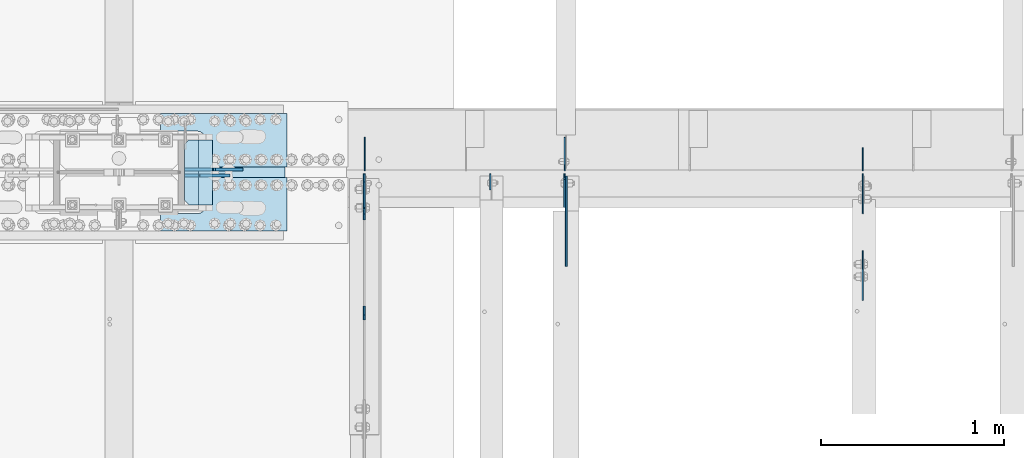
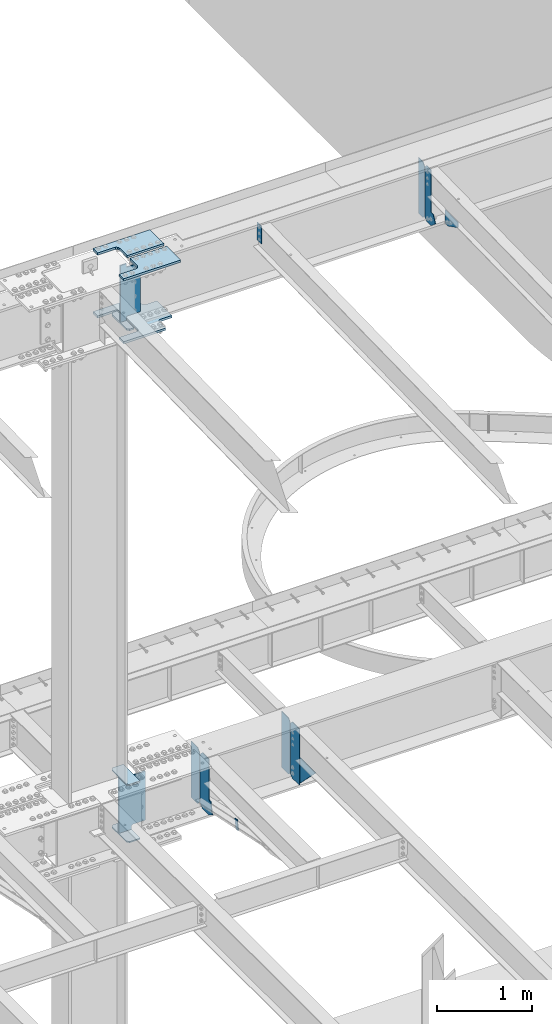
# One storey, part 1619 of 1763: 18 plates, 9 elements without a shape of their own.
"""IFC2X3 building model written with IfcOpenShell, lengths in millimetres."""

import ifcopenshell
import ifcopenshell.guid

model = None  # the IFC model being written
_history = None  # IfcOwnerHistory: only IFC2X3 demands one
_inside = {}  # id of a spatial element -> (the spatial element, [elements in it])
_under = {}  # id of a project, library or spatial element -> (it, [spatial elements below it])
_declared = {}  # id of a project -> (the project, [libraries it declares])
_typed = {}  # id of a type object -> (the type object, [elements of that type])
_made_of = {}  # id of a material, layer set ... -> (it, [elements and type objects made of it])


def new_model(schema):
    """Start an empty IFC model of exactly this schema.

    Asked for "IFC4X3", IfcOpenShell would pick the latest addendum, in which some entities
    have other attributes; the version numbers below select the first issue.
    IFC2X3 requires an IfcOwnerHistory on every rooted entity: one is made here for all.
    """
    global model, _history
    if schema == "IFC4X3":
        model = ifcopenshell.file(schema_version=(4, 3, 0, 0))
    else:
        model = ifcopenshell.file(schema=schema)
    _inside.clear()
    _under.clear()
    _declared.clear()
    _typed.clear()
    _made_of.clear()
    _history = None
    if model.schema == "IFC2X3":
        org = make("IfcOrganization", Name="unknown")
        user = make(
            "IfcPersonAndOrganization",
            ThePerson=make("IfcPerson", FamilyName="unknown"),
            TheOrganization=org,
        )
        app = make(
            "IfcApplication",
            ApplicationDeveloper=org,
            Version="unknown",
            ApplicationFullName="unknown",
            ApplicationIdentifier="unknown",
        )
        _history = make(
            "IfcOwnerHistory",
            OwningUser=user,
            OwningApplication=app,
            ChangeAction="ADDED",
            CreationDate=0,
        )
    return model


def make(cls, **values):
    """One entity of the class cls with the attributes given. An attribute that is None is left unset."""
    return model.create_entity(
        cls, **{name: value for name, value in values.items() if value is not None}
    )


def rooted(cls, **values):
    """An entity with a GlobalId (a new one), such as an element, a storey or a relation."""
    return make(cls, GlobalId=ifcopenshell.guid.new(), OwnerHistory=_history, **values)


def si_unit(unit_type, name, prefix=None):
    """IfcSIUnit, for example si_unit("LENGTHUNIT", "METRE", prefix="MILLI")."""
    return make("IfcSIUnit", UnitType=unit_type, Prefix=prefix, Name=name)


def assignment(units):
    """IfcUnitAssignment: the units of a project."""
    return None if units is None else make("IfcUnitAssignment", Units=units)


def point(xyz):
    """IfcCartesianPoint."""
    return None if xyz is None else make("IfcCartesianPoint", Coordinates=xyz)


def direction(xyz):
    """IfcDirection."""
    return None if xyz is None else make("IfcDirection", DirectionRatios=xyz)


def frame(location, z_axis=None, x_axis=None):
    """IfcAxis2Placement3D, a coordinate frame: its origin and axes. An axis left out is left unset."""
    return make(
        "IfcAxis2Placement3D",
        Location=point(location),
        Axis=direction(z_axis),
        RefDirection=direction(x_axis),
    )


def origin_with_axes():
    """The frame at (0, 0, 0) with the z axis (0, 0, 1) and the x axis (1, 0, 0) written out."""
    return frame((0.0, 0.0, 0.0), z_axis=(0.0, 0.0, 1.0), x_axis=(1.0, 0.0, 0.0))


def place(relative_to, where):
    """IfcLocalPlacement: puts the frame where relative to a parent placement (None: the world)."""
    return make(
        "IfcLocalPlacement", PlacementRelTo=relative_to, RelativePlacement=where
    )


def context(
    kind, dimensions, precision=None, world=None, true_north=None, identifier=None
):
    """IfcGeometricRepresentationContext, for example the 3D "Model" context."""
    return make(
        "IfcGeometricRepresentationContext",
        ContextIdentifier=identifier,
        ContextType=kind,
        CoordinateSpaceDimension=dimensions,
        Precision=precision,
        WorldCoordinateSystem=world,
        TrueNorth=true_north,
    )


def subcontext(parent, identifier, kind, view, scale=None):
    """IfcGeometricRepresentationSubContext, for example "Body" below "Model"."""
    return make(
        "IfcGeometricRepresentationSubContext",
        ContextIdentifier=identifier,
        ContextType=kind,
        ParentContext=parent,
        TargetScale=scale,
        TargetView=view,
    )


def project(units=None, contexts=None):
    """IfcProject with its units and contexts."""
    return rooted(
        "IfcProject",
        Name="project",
        RepresentationContexts=contexts,
        UnitsInContext=assignment(units),
    )


def spatial(cls, under=None, at=None, **own):
    """A site, building, storey or space (cls), placed at a placement, below another one or the project."""
    s = rooted(cls, ObjectPlacement=at, **own)
    if under is not None:
        _under.setdefault(under.id(), (under, []))[1].append(s)
    return s


def faces_of(points, faces, orient=None, outer=None):
    """IfcFace entities. A face is a list of loops; a loop is a list of indices into points, from 0.

    orient and outer hold one flag for each loop. By default every Orientation is true, the
    first loop of a face is its IfcFaceOuterBound and the others are IfcFaceBound.
    """
    made = []
    for i, loops in enumerate(faces):
        bounds = []
        for j, loop in enumerate(loops):
            is_outer = j == 0 if outer is None else outer[i][j]
            bounds.append(
                make(
                    "IfcFaceOuterBound" if is_outer else "IfcFaceBound",
                    Bound=make("IfcPolyLoop", Polygon=[points[k] for k in loop]),
                    Orientation=True if orient is None else orient[i][j],
                )
            )
        made.append(make("IfcFace", Bounds=bounds))
    return made


def faceted_brep(points, faces, orient=None, outer=None, voids=None):
    """IfcFacetedBrep: a solid bounded by flat faces; with voids (closed shells), ...WithVoids."""
    shared = [point(p) for p in points]
    hull = make("IfcClosedShell", CfsFaces=faces_of(shared, faces, orient, outer))
    if voids is None:
        return make("IfcFacetedBrep", Outer=hull)
    return make(
        "IfcFacetedBrepWithVoids",
        Outer=hull,
        Voids=[
            make(cls, CfsFaces=faces_of(shared, fs, o, b)) for cls, fs, o, b in voids
        ],
    )


def shape(context_of_items, identifier, shape_type, items):
    """IfcShapeRepresentation: the items that make up one representation, for example the "Body"."""
    return make(
        "IfcShapeRepresentation",
        ContextOfItems=context_of_items,
        RepresentationIdentifier=identifier,
        RepresentationType=shape_type,
        Items=items,
    )


def material(Name=None, Category=None):
    """IfcMaterial."""
    return make("IfcMaterial", Name=Name, Category=Category)


def made_of(thing, what):
    """Note that an element or type object is made of a material, layer set ...; save() writes the relation."""
    if what is not None:
        _made_of.setdefault(what.id(), (what, []))[1].append(thing)
    return thing


def type_object(cls, material=None, **own):
    """A type object (cls), such as IfcWallType, which elements share."""
    return made_of(rooted(cls, **own), material)


def element(
    cls,
    number,
    at=None,
    inside=None,
    cuts=None,
    type_object=None,
    material=None,
    context=None,
    identifier="Body",
    shape_type=None,
    held_by="IfcProductDefinitionShape",
    body=None,
    shapes=None,
    **own,
):
    """One element of the class cls, such as IfcWall. Its Tag is "e" and its number.

    at: its placement. inside: the storey or other place that contains it. cuts: it is an
    opening in that element (IfcRelVoidsElement). A single representation is given by context,
    identifier, shape_type and body (its items); several are given by shapes. held_by: the class
    of the entity that holds the representations. save() writes the other relations.
    """
    e = rooted(cls, Tag="e%d" % number, ObjectPlacement=at, **own)
    if body is not None:
        shapes = [shape(context, identifier, shape_type, body)]
    if shapes is not None:
        e.Representation = make(held_by, Representations=shapes)
    if inside is not None:
        _inside.setdefault(inside.id(), (inside, []))[1].append(e)
    if cuts is not None:
        rooted(
            "IfcRelVoidsElement", RelatingBuildingElement=cuts, RelatedOpeningElement=e
        )
    if type_object is not None:
        _typed.setdefault(type_object.id(), (type_object, []))[1].append(e)
    return made_of(e, material)


def aggregate(whole, parts):
    """IfcRelAggregates: a whole, such as a stair, and the parts it consists of."""
    return rooted("IfcRelAggregates", RelatingObject=whole, RelatedObjects=parts)


def save(model, path):
    """Write the relations noted so far, then the file.

    IfcRelAggregates (storeys below a building ...), IfcRelContainedInSpatialStructure (elements
    in a storey), IfcRelDefinesByType, IfcRelAssociatesMaterial and IfcRelDeclares: one each for
    every whole, place, type object, material and project.
    """
    for whole, parts in _under.values():
        aggregate(whole, parts)
    for where, things in _inside.values():
        rooted(
            "IfcRelContainedInSpatialStructure",
            RelatedElements=things,
            RelatingStructure=where,
        )
    for kind, things in _typed.values():
        rooted("IfcRelDefinesByType", RelatedObjects=things, RelatingType=kind)
    for what, things in _made_of.values():
        rooted("IfcRelAssociatesMaterial", RelatedObjects=things, RelatingMaterial=what)
    for by, libraries in _declared.values():
        rooted("IfcRelDeclares", RelatingContext=by, RelatedDefinitions=libraries)
    model.write(path)


model = new_model("IFC2X3")

# Units and contexts
model_context = context("Model", 3, precision=1e-05, world=origin_with_axes())
body_context = subcontext(model_context, "Body", "Model", "MODEL_VIEW")
ifc_project = project(units=[si_unit("LENGTHUNIT", "METRE", prefix="MILLI"), si_unit("AREAUNIT", "SQUARE_METRE"), si_unit("VOLUMEUNIT", "CUBIC_METRE"), si_unit("MASSUNIT", "GRAM", prefix="KILO"), si_unit("TIMEUNIT", "SECOND"), si_unit("PLANEANGLEUNIT", "RADIAN"), si_unit("SOLIDANGLEUNIT", "STERADIAN"), si_unit("THERMODYNAMICTEMPERATUREUNIT", "DEGREE_CELSIUS"), si_unit("LUMINOUSINTENSITYUNIT", "LUMEN")], contexts=[model_context])

# Site, building, storey
site_placement = place(None, origin_with_axes())
site = spatial("IfcSite", under=ifc_project, at=site_placement, CompositionType="ELEMENT")
building_placement = place(site_placement, origin_with_axes())
building = spatial("IfcBuilding", under=site, at=building_placement, Name="Undefined", CompositionType="ELEMENT")
storey_placement = place(building_placement, origin_with_axes())
storey = spatial("IfcBuildingStorey", under=building, at=storey_placement, Name="Undefined", CompositionType="ELEMENT", Elevation=0.0)

# Assembly, plate
assembly_1_placement = place(storey_placement, origin_with_axes())
assembly_1 = element("IfcElementAssembly", 1, at=assembly_1_placement, inside=storey, Name="ANGLE BRACE", AssemblyPlace="NOTDEFINED", PredefinedType="RIGID_FRAME")
ifc_material_1 = material(Name="STEEL/A36")
plate_type_1 = type_object("IfcPlateType", PredefinedType="NOTDEFINED")
plate_1_placement = place(assembly_1_placement, frame((-60256.1747736983, 51342.4281032895, 4746.91590772782), z_axis=(0.0, -0.208168683014592, -0.978092940068566), x_axis=(0.0, 0.978092940068566, -0.208168683014588)))
plate_1 = element("IfcPlate", 2, at=plate_1_placement, type_object=plate_type_1, material=ifc_material_1, Name="PLATE", context=body_context, shape_type="Brep", body=[
    faceted_brep([(0.0, -4.76249999999982, 0.0), (2.11002770811319e-09, -4.76249999999709, 127.040328979458), (2.11002770811319e-09, 4.76249999999709, 127.040328979458), (0.0, 4.76249999999982, 0.0), (50.7119293213109, -4.76249999999709, 126.999992370584), (50.7119293213109, 4.76249999999709, 126.999992370584), (50.7119293211581, -4.76249999999709, 1.63709046319127e-11), (50.7119293211581, 4.76249999999709, 1.63709046319127e-11)], [[[0, 1, 2, 3]], [[1, 4, 5, 2]], [[4, 6, 7, 5]], [[6, 0, 3, 7]], [[5, 7, 3, 2]], [[6, 4, 1, 0]]]),
])
aggregate(assembly_1, [plate_1])

assembly_2_placement = place(storey_placement, origin_with_axes())
assembly_2 = element("IfcElementAssembly", 3, at=assembly_2_placement, inside=storey, Name="BEAM", AssemblyPlace="NOTDEFINED", PredefinedType="RIGID_FRAME")
plate_type_2 = type_object("IfcPlateType", PredefinedType="NOTDEFINED")
plate_2_placement = place(assembly_2_placement, frame((-57536.787273746, 52128.7375017387, 11001.3749917654), z_axis=(0.0, 0.0, 1.0), x_axis=(0.0, 1.0, 0.0)))
plate_2 = element("IfcPlate", 4, at=plate_2_placement, type_object=plate_type_2, material=ifc_material_1, Name="PLATE", context=body_context, shape_type="Brep", body=[
    faceted_brep([(0.0, -3.17500000000291, 31.75), (0.0, -3.17500000000291, 682.625), (0.0, 3.17500000000291, 682.625), (0.0, 3.17500000000291, 31.75), (31.75, -3.17500000000291, 714.375), (31.75, 3.17500000000291, 714.375), (125.412498474121, -3.17500000000291, 714.375), (125.412498474121, 3.17500000000291, 714.375), (125.412498474121, -3.17500000000291, 0.0), (125.412498474121, 3.17500000000291, 0.0), (31.7499999999036, -3.17499999997381, 9.42916855706244e-11), (31.7499999998854, 3.17500000000291, 9.42916855706244e-11)], [[[0, 1, 2, 3]], [[1, 4, 5, 2]], [[4, 6, 7, 5]], [[6, 8, 9, 7]], [[8, 10, 11, 9]], [[10, 0, 3, 11]], [[5, 7, 9, 11, 3, 2]], [[10, 8, 6, 4, 1, 0]]]),
])

# Assembly, plates
assembly_3_placement = place(storey_placement, origin_with_axes())
assembly_3 = element("IfcElementAssembly", 5, at=assembly_3_placement, inside=storey, Name="BEAM", AssemblyPlace="NOTDEFINED", PredefinedType="RIGID_FRAME")
plate_type_3 = type_object("IfcPlateType", PredefinedType="NOTDEFINED")
plate_3_placement = place(assembly_3_placement, frame((-60254.587273746, 52128.7375, 4448.175), z_axis=(0.0, 0.0, 1.0), x_axis=(0.0, 1.0, 0.0)))
plate_3 = element("IfcPlate", 6, at=plate_3_placement, type_object=plate_type_3, material=ifc_material_1, Name="PLATE", context=body_context, shape_type="Brep", body=[
    faceted_brep([(0.0, -3.17500000000291, 44.4500000000007), (0.0, -3.17500000000291, 673.099987030029), (0.0, 3.17500000000291, 673.099987030029), (0.0, 3.17500000000291, 44.4500000000007), (44.4500007629395, -3.17500000000291, 717.549987792969), (44.4500007629395, 3.17500000000291, 717.549987792969), (182.5625, -3.17500000000291, 717.549987792969), (182.5625, 3.17500000000291, 717.549987792969), (182.5625, -3.17500000000291, 0.0), (182.5625, 3.17500000000291, 0.0), (44.4500007629395, -3.17500000000291, 0.0), (44.4500007629395, 3.17500000000291, 0.0)], [[[0, 1, 2, 3]], [[1, 4, 5, 2]], [[4, 6, 7, 5]], [[6, 8, 9, 7]], [[8, 10, 11, 9]], [[10, 0, 3, 11]], [[5, 7, 9, 11, 3, 2]], [[10, 8, 6, 4, 1, 0]]]),
])
plate_4_placement = place(assembly_3_placement, frame((-59162.387273746, 52128.7375, 4448.175), z_axis=(0.0, 0.0, 1.0), x_axis=(0.0, 1.0, 0.0)))
plate_4 = element("IfcPlate", 7, at=plate_4_placement, type_object=plate_type_3, material=ifc_material_1, Name="PLATE", context=body_context, shape_type="Brep", body=[
    faceted_brep([(0.0, -3.17500000000291, 31.75), (0.0, -3.17500000000291, 687.387512207031), (0.0, 3.17500000000291, 687.387512207031), (0.0, 3.17500000000291, 31.75), (31.75, -3.17500000000291, 719.137512207031), (31.75, 3.17500000000291, 719.137512207031), (182.5625, -3.17500000000291, 719.137512207031), (182.5625, 3.17500000000291, 719.137512207031), (182.5625, -3.17500000000291, 0.0), (182.5625, 3.17500000000291, 0.0), (31.7499999999036, -3.17499999997381, 9.42916855706244e-11), (31.7499999998854, 3.17500000000291, 9.42916855706244e-11)], [[[0, 1, 2, 3]], [[1, 4, 5, 2]], [[4, 6, 7, 5]], [[6, 8, 9, 7]], [[8, 10, 11, 9]], [[10, 0, 3, 11]], [[5, 7, 9, 11, 3, 2]], [[10, 8, 6, 4, 1, 0]]]),
])
plate_type_4 = type_object("IfcPlateType", PredefinedType="NOTDEFINED")
plate_5_placement = place(assembly_3_placement, frame((-59163.1820237632, 52112.8625, 4448.175), z_axis=(0.0, 0.0, 1.0), x_axis=(0.0, -1.0, 0.0)))
plate_5 = element("IfcPlate", 8, at=plate_5_placement, type_object=plate_type_4, material=ifc_material_1, Name="PLATE", context=body_context, shape_type="Brep", body=[
    faceted_brep([(0.0, -3.96899999999732, 31.75), (0.0, -3.96899999999732, 687.387512207031), (0.0, 3.96899999999732, 687.387512207031), (0.0, 3.96899999999732, 31.75), (31.75, -3.96899999999732, 719.137512207031), (31.75, 3.96899999999732, 719.137512207031), (182.5625, -3.96899999999732, 719.137512207031), (182.5625, 3.96899999999732, 719.137512207031), (182.5625, -3.96899999999732, 0.0), (182.5625, 3.96899999999732, 0.0), (31.75, -3.96899999999732, 0.0), (31.75, 3.96899999999732, 0.0)], [[[0, 1, 2, 3]], [[1, 4, 5, 2]], [[4, 6, 7, 5]], [[6, 8, 9, 7]], [[8, 10, 11, 9]], [[10, 0, 3, 11]], [[5, 7, 9, 11, 3, 2]], [[10, 8, 6, 4, 1, 0]]]),
])

# Assembly, plate
assembly_4_placement = place(storey_placement, origin_with_axes())
assembly_4 = element("IfcElementAssembly", 9, at=assembly_4_placement, inside=storey, Name="BEAM", AssemblyPlace="NOTDEFINED", PredefinedType="RIGID_FRAME")
plate_type_5 = type_object("IfcPlateType", PredefinedType="NOTDEFINED")
plate_6_placement = place(assembly_4_placement, frame((-59154.449773746, 51930.3004272461, 4794.2499684514), z_axis=(0.0, 0.0, -1.0), x_axis=(0.0, -1.0, 0.0)))
plate_6 = element("IfcPlate", 10, at=plate_6_placement, type_object=plate_type_5, material=ifc_material_1, Name="PLATE", context=body_context, shape_type="Brep", body=[
    faceted_brep([(0.0, -4.76249999999982, 0.0), (-169.862075805664, -4.76249999999709, 6.30279828328639e-10), (-169.862075805664, 4.76249999999709, 6.30279828328639e-10), (0.0, 4.76249999999982, 0.0), (-169.862091064453, -4.76249999999709, 323.002471923828), (-169.862091064453, 4.76249999999709, 323.002471923828), (6.38101482763886e-09, -4.76249999999709, 323.002471923828), (6.38101482763886e-09, 4.76249999999709, 323.002471923828), (322.262145996094, -4.76249999999709, -1.15778675535694e-09), (322.262145996094, 4.76249999999709, -1.15778675535694e-09)], [[[0, 1, 2, 3]], [[1, 4, 5, 2]], [[4, 6, 7, 5]], [[6, 8, 9, 7]], [[8, 0, 3, 9]], [[5, 7, 9, 3, 2]], [[8, 6, 4, 1, 0]]]),
])
aggregate(assembly_4, [plate_6])

# Assembly, plates
assembly_5_placement = place(storey_placement, origin_with_axes())
assembly_5 = element("IfcElementAssembly", 11, at=assembly_5_placement, inside=storey, Name="COLUMN", AssemblyPlace="NOTDEFINED", PredefinedType="RIGID_FRAME")
ifc_material_2 = material(Name="STEEL/A572-50")
plate_type_6 = type_object("IfcPlateType", PredefinedType="NOTDEFINED")
plate_7_placement = place(assembly_5_placement, frame((-61084.8497798019, 52298.6, 5157.7875), z_axis=(-1.0, 0.0, 0.0), x_axis=(0.0, -1.0, 0.0)))
plate_7 = element("IfcPlate", 12, at=plate_7_placement, type_object=plate_type_6, material=ifc_material_2, Name="PLATE", context=body_context, shape_type="Brep", body=[
    faceted_brep([(-7.27595761418343e-12, -7.9375, 0.0), (0.0, -7.9375, 126.999994277954), (0.0, 7.9375, 126.999994277954), (-7.27595761418343e-12, 7.9375, 0.0), (25.3999996185303, -7.9375, 152.399993896484), (25.3999996185303, 7.9375, 152.399993896484), (330.200006484985, -7.9375, 152.399993896484), (330.200006484985, 7.9375, 152.399993896484), (355.600006103516, -7.9375, 126.999994277954), (355.600006103516, 7.9375, 126.999994277954), (355.600006103516, -7.9375, 0.0), (355.600006103516, 7.9375, 0.0)], [[[0, 1, 2, 3]], [[1, 4, 5, 2]], [[4, 6, 7, 5]], [[6, 8, 9, 7]], [[8, 10, 11, 9]], [[10, 0, 3, 11]], [[5, 7, 9, 11, 3, 2]], [[10, 8, 6, 4, 1, 0]]]),
])
plate_8_placement = place(assembly_5_placement, frame((-61084.8497798019, 52298.6, 4427.5375), z_axis=(-1.0, 0.0, 0.0), x_axis=(0.0, -1.0, 0.0)))
plate_8 = element("IfcPlate", 13, at=plate_8_placement, type_object=plate_type_6, material=ifc_material_2, Name="PLATE", context=body_context, shape_type="Brep", body=[
    faceted_brep([(-7.27595761418343e-12, -7.9375, 0.0), (0.0, -7.9375, 126.999994277954), (0.0, 7.9375, 126.999994277954), (-7.27595761418343e-12, 7.9375, 0.0), (25.3999996185303, -7.9375, 152.399993896484), (25.3999996185303, 7.9375, 152.399993896484), (330.200006484985, -7.9375, 152.399993896484), (330.200006484985, 7.9375, 152.399993896484), (355.600006103516, -7.9375, 126.999994277954), (355.600006103516, 7.9375, 126.999994277954), (355.600006103516, -7.9375, 0.0), (355.600006103516, 7.9375, 0.0)], [[[0, 1, 2, 3]], [[1, 4, 5, 2]], [[4, 6, 7, 5]], [[6, 8, 9, 7]], [[8, 10, 11, 9]], [[10, 0, 3, 11]], [[5, 7, 9, 11, 3, 2]], [[10, 8, 6, 4, 1, 0]]]),
])

# Assembly, plate
assembly_6_placement = place(storey_placement, origin_with_axes())
assembly_6 = element("IfcElementAssembly", 14, at=assembly_6_placement, inside=storey, Name="PLATE", AssemblyPlace="NOTDEFINED", PredefinedType="RIGID_FRAME")
plate_type_7 = type_object("IfcPlateType", PredefinedType="NOTDEFINED")
plate_9_placement = place(assembly_6_placement, frame((-61367.4247736983, 51800.1250002128, 10955.3374917654), z_axis=(0.0, 1.0, 0.0), x_axis=(1.0, 0.0, 0.0)))
plate_9 = element("IfcPlate", 15, at=plate_9_placement, type_object=plate_type_7, material=ifc_material_2, Name="PLATE", context=body_context, shape_type="Brep", body=[
    faceted_brep([(0.0, -14.2875000000058, 0.0), (0.0, -14.2875000000004, 95.25), (0.0, 14.2875000000004, 95.25), (0.0, 14.2875000000058, 0.0), (209.550006866455, -14.2875000000004, 95.25), (209.550006866455, 14.2875000000004, 95.25), (220.342425159237, -14.2875000000004, 96.9593511310522), (220.342425159237, 14.2875000000004, 96.9593511310522), (230.078406354325, -14.2875000000004, 101.920081325748), (230.078406354325, 14.2875000000004, 101.920081325748), (237.804924777767, -14.2875000000004, 109.646599749191), (237.804924777767, 14.2875000000004, 109.646599749191), (242.765654972463, -14.2875000000004, 119.382580944279), (242.765654972463, 14.2875000000004, 119.382580944279), (244.475006103516, -14.2875000000004, 130.174999237061), (244.475006103516, 14.2875000000004, 130.174999237061), (244.475006103516, -14.2875000000004, 511.174976348877), (244.475006103516, 14.2875000000004, 511.174976348877), (242.765654972463, -14.2875000000004, 521.967394641659), (242.765654972463, 14.2875000000004, 521.967394641659), (237.804924777767, -14.2875000000004, 531.703375836747), (237.804924777767, 14.2875000000004, 531.703375836747), (230.078406354325, -14.2875000000004, 539.429894260189), (230.078406354325, 14.2875000000004, 539.429894260189), (220.342425159237, -14.2875000000004, 544.390624454885), (220.342425159237, 14.2875000000004, 544.390624454885), (209.550006866455, -14.2875000000004, 546.099975585938), (209.550006866455, 14.2875000000004, 546.099975585938), (0.0, -14.2875000000004, 546.099975585938), (0.0, 14.2875000000004, 546.099975585938), (0.0, -14.2875000000004, 641.349975585938), (0.0, 14.2875000000004, 641.349975585938), (508.0, -14.2875000000004, 641.349975585938), (508.0, 14.2875000000004, 641.349975585938), (508.0, -14.2875000000004, 511.174999237061), (508.0, 14.2875000000004, 511.174999237061), (509.709351131052, -14.2875000000004, 500.382580944279), (509.709351131052, 14.2875000000004, 500.382580944279), (514.670081325748, -14.2875000000004, 490.646599749191), (514.670081325748, 14.2875000000004, 490.646599749191), (522.396599749191, -14.2875000000004, 482.920081325748), (522.396599749191, 14.2875000000004, 482.920081325748), (532.132580944279, -14.2875000000004, 477.959351131052), (532.132580944279, 14.2875000000004, 477.959351131052), (542.924999237061, -14.2875000000004, 476.25), (542.924999237061, 14.2875000000004, 476.25), (679.450012207031, -14.2875000000004, 476.25), (679.450012207031, 14.2875000000004, 476.25), (679.450012207031, -14.2875000000004, 165.100006103516), (679.450012207031, 14.2875000000004, 165.100006103516), (542.924999237061, -14.2875000000004, 165.100006103516), (542.924999237061, 14.2875000000004, 165.100006103516), (532.132580944279, -14.2875000000004, 163.390654972463), (532.132580944279, 14.2875000000004, 163.390654972463), (522.396599749191, -14.2875000000004, 158.429924777767), (522.396599749191, 14.2875000000004, 158.429924777767), (514.670081325748, -14.2875000000004, 150.703406354325), (514.670081325748, 14.2875000000004, 150.703406354325), (509.709351131052, -14.2875000000004, 140.967425159237), (509.709351131052, 14.2875000000004, 140.967425159237), (508.0, -14.2875000000004, 130.175006866455), (508.0, 14.2875000000004, 130.175006866455), (508.0, -14.2875000000004, 0.0), (508.0, 14.2875000000004, 0.0)], [[[0, 1, 2, 3]], [[1, 4, 5, 2]], [[4, 6, 7, 5]], [[6, 8, 9, 7]], [[8, 10, 11, 9]], [[10, 12, 13, 11]], [[12, 14, 15, 13]], [[14, 16, 17, 15]], [[16, 18, 19, 17]], [[18, 20, 21, 19]], [[20, 22, 23, 21]], [[22, 24, 25, 23]], [[24, 26, 27, 25]], [[26, 28, 29, 27]], [[28, 30, 31, 29]], [[30, 32, 33, 31]], [[32, 34, 35, 33]], [[34, 36, 37, 35]], [[36, 38, 39, 37]], [[38, 40, 41, 39]], [[40, 42, 43, 41]], [[42, 44, 45, 43]], [[44, 46, 47, 45]], [[46, 48, 49, 47]], [[48, 50, 51, 49]], [[50, 52, 53, 51]], [[52, 54, 55, 53]], [[54, 56, 57, 55]], [[56, 58, 59, 57]], [[58, 60, 61, 59]], [[60, 62, 63, 61]], [[62, 0, 3, 63]], [[5, 7, 9, 11, 13, 15, 17, 19, 21, 23, 25, 27, 29, 31, 33, 35, 37, 39, 41, 43, 45, 47, 49, 51, 53, 55, 57, 59, 61, 63, 3, 2]], [[62, 60, 58, 56, 54, 52, 50, 48, 46, 44, 42, 40, 38, 36, 34, 32, 30, 28, 26, 24, 22, 20, 18, 16, 14, 12, 10, 8, 6, 4, 1, 0]]]),
])
aggregate(assembly_6, [plate_9])

assembly_7_placement = place(storey_placement, origin_with_axes())
assembly_7 = element("IfcElementAssembly", 16, at=assembly_7_placement, inside=storey, Name="TOP PLATE", AssemblyPlace="NOTDEFINED", PredefinedType="RIGID_FRAME")
plate_type_8 = type_object("IfcPlateType", PredefinedType="NOTDEFINED")
plate_10_placement = place(assembly_7_placement, frame((-60678.4497736983, 52092.2250002128, 11761.7874917654), z_axis=(0.0, -1.0, 0.0), x_axis=(-1.0, 0.0, 0.0)))
plate_10 = element("IfcPlate", 17, at=plate_10_placement, type_object=plate_type_8, material=ifc_material_2, Name="TOP PLATE", context=body_context, shape_type="Brep", body=[
    faceted_brep([(0.0, -14.2875000000058, 0.0), (0.0, -14.2875000000004, 292.100006103516), (0.0, 14.2875000000004, 292.100006103516), (0.0, 14.2875000000058, 0.0), (688.974975585938, -14.2875000000004, 292.100006103516), (688.974975585938, 14.2875000000004, 292.100006103516), (688.974975585938, -14.2875000000004, 196.850006103516), (688.974975585938, 14.2875000000004, 196.850006103516), (488.950000762939, -14.2875000000004, 196.850006103516), (488.950000762939, 14.2875000000004, 196.850006103516), (471.939721902345, -14.2875000000004, 193.466451265565), (471.939721902345, 14.2875000000004, 193.466451265565), (457.519103799721, -14.2875000000004, 183.830902303795), (457.519103799721, 14.2875000000004, 183.830902303795), (447.88355483795, -14.2875000000004, 169.410284201171), (447.88355483795, 14.2875000000004, 169.410284201171), (444.5, -14.2875000000004, 152.400005340576), (444.5, 14.2875000000004, 152.400005340576), (444.5, -14.2875000000004, 0.0), (444.5, 14.2875000000004, 0.0)], [[[0, 1, 2, 3]], [[1, 4, 5, 2]], [[4, 6, 7, 5]], [[6, 8, 9, 7]], [[8, 10, 11, 9]], [[10, 12, 13, 11]], [[12, 14, 15, 13]], [[14, 16, 17, 15]], [[16, 18, 19, 17]], [[18, 0, 3, 19]], [[5, 7, 9, 11, 13, 15, 17, 19, 3, 2]], [[18, 16, 14, 12, 10, 8, 6, 4, 1, 0]]]),
])
aggregate(assembly_7, [plate_10])

assembly_8_placement = place(storey_placement, origin_with_axes())
assembly_8 = element("IfcElementAssembly", 18, at=assembly_8_placement, inside=storey, Name="TOP PLATE", AssemblyPlace="NOTDEFINED", PredefinedType="RIGID_FRAME")
plate_11_placement = place(assembly_8_placement, frame((-61122.9497736983, 52149.3750002128, 11761.7874917654), z_axis=(0.0, 1.0, 0.0), x_axis=(1.0, 0.0, 0.0)))
plate_11 = element("IfcPlate", 19, at=plate_11_placement, type_object=plate_type_8, material=ifc_material_2, Name="TOP PLATE", context=body_context, shape_type="Brep", body=[
    faceted_brep([(0.0, -14.2875000000058, 0.0), (0.0, -14.2875000000004, 152.400001525879), (0.0, 14.2875000000004, 152.400001525879), (0.0, 14.2875000000058, 0.0), (-3.38355483795021, -14.2875000000004, 169.410284201171), (-3.38355483795021, 14.2875000000004, 169.410284201171), (-13.0191037997211, -14.2875000000004, 183.830902303795), (-13.0191037997211, 14.2875000000004, 183.830902303795), (-27.4397219023449, -14.2875000000004, 193.466451265565), (-27.4397219023449, 14.2875000000004, 193.466451265565), (-44.4500007629395, -14.2875000000004, 196.850006103516), (-44.4500007629395, 14.2875000000004, 196.850006103516), (-244.475006103516, -14.2875000000004, 196.850006103516), (-244.475006103516, 14.2875000000004, 196.850006103516), (-244.475006103516, -14.2875000000004, 292.100006103516), (-244.475006103516, 14.2875000000004, 292.100006103516), (444.5, -14.2875000000004, 292.100006103516), (444.5, 14.2875000000004, 292.100006103516), (444.5, -14.2875000000004, 0.0), (444.5, 14.2875000000004, 0.0)], [[[0, 1, 2, 3]], [[1, 4, 5, 2]], [[4, 6, 7, 5]], [[6, 8, 9, 7]], [[8, 10, 11, 9]], [[10, 12, 13, 11]], [[12, 14, 15, 13]], [[14, 16, 17, 15]], [[16, 18, 19, 17]], [[18, 0, 3, 19]], [[5, 7, 9, 11, 13, 15, 17, 19, 3, 2]], [[18, 16, 14, 12, 10, 8, 6, 4, 1, 0]]]),
])
aggregate(assembly_8, [plate_11])

# Plate
plate_type_9 = type_object("IfcPlateType", PredefinedType="NOTDEFINED")
plate_12_placement = place(assembly_5_placement, frame((-61237.2497736983, 52298.6, 10980.7374917654), z_axis=(1.0, 0.0, 0.0), x_axis=(0.0, -1.0, 0.0)))
plate_12 = element("IfcPlate", 20, at=plate_12_placement, type_object=plate_type_9, material=ifc_material_2, Name="BRIDGE PLATE", context=body_context, shape_type="Brep", body=[
    faceted_brep([(0.0, -11.1124999999993, 25.3999996185303), (0.0, -11.1124999999993, 76.1999969482422), (0.0, 11.1124999999993, 76.1999969482422), (0.0, 11.1124999999993, 25.3999996185303), (355.600006103516, -11.1124999999993, 76.1999969482422), (355.600006103516, 11.1124999999993, 76.1999969482422), (355.600006103516, -11.1124999999993, 25.3999996185303), (355.600006103516, 11.1124999999993, 25.3999996185303), (330.200006484985, -11.1124999999993, 0.0), (330.200006484985, 11.1124999999993, 0.0), (25.3999996185303, -11.1124999999993, 0.0), (25.3999996185303, 11.1124999999993, 0.0)], [[[0, 1, 2, 3]], [[1, 4, 5, 2]], [[4, 6, 7, 5]], [[6, 8, 9, 7]], [[8, 10, 11, 9]], [[10, 0, 3, 11]], [[5, 7, 9, 11, 3, 2]], [[10, 8, 6, 4, 1, 0]]]),
])

plate_type_10 = type_object("IfcPlateType", PredefinedType="NOTDEFINED")
plate_13_placement = place(assembly_5_placement, frame((-60989.5997736983, 52104.9250002128, 11045.8249917654), z_axis=(-1.0, 0.0, 0.0), x_axis=(0.0, 0.0, 1.0)))
plate_13 = element("IfcPlate", 21, at=plate_13_placement, type_object=plate_type_10, material=ifc_material_2, Name="SHEAR TAB", context=body_context, shape_type="Brep", body=[
    faceted_brep([(-7.27595761418343e-12, -7.9375, 0.0), (0.0, -7.9375, 158.749997138977), (0.0, 7.9375, 158.749997138977), (-7.27595761418343e-12, 7.9375, 0.0), (-0.966729922587547, -7.9375, 163.610076657023), (-0.966729922587547, 7.9375, 163.610076657023), (-3.71974382306507, -7.9375, 167.730253125177), (-3.71974382306507, 7.9375, 167.730253125177), (-7.83992029121873, -7.9375, 170.483267025651), (-7.83992029121873, 7.9375, 170.483267025651), (-12.6999998092651, -7.9375, 171.449996948242), (-12.6999998092651, 7.9375, 171.449996948242), (-53.9749984741211, -7.9375, 171.449996948242), (-53.9749984741211, 7.9375, 171.449996948242), (-53.9749984741211, -7.9375, 247.649993896484), (-53.9749984741211, 7.9375, 247.649993896484), (671.512451171875, -7.9375, 247.649993896484), (671.512451171875, 7.9375, 247.649993896484), (671.512451171875, -7.9375, 171.449996948242), (671.512451171875, 7.9375, 171.449996948242), (638.174975395203, -7.9375, 171.449996948242), (638.174975395203, 7.9375, 171.449996948242), (633.314895877156, -7.9375, 170.483267025651), (633.314895877156, 7.9375, 170.483267025651), (629.194719409003, -7.9375, 167.730253125177), (629.194719409003, 7.9375, 167.730253125177), (626.441705508525, -7.9375, 163.610076657023), (626.441705508525, 7.9375, 163.610076657023), (625.474975585938, -7.9375, 158.749997138977), (625.474975585938, 7.9375, 158.749997138977), (625.474975585938, -7.9375, 0.0), (625.474975585938, 7.9375, 0.0)], [[[0, 1, 2, 3]], [[1, 4, 5, 2]], [[4, 6, 7, 5]], [[6, 8, 9, 7]], [[8, 10, 11, 9]], [[10, 12, 13, 11]], [[12, 14, 15, 13]], [[14, 16, 17, 15]], [[16, 18, 19, 17]], [[18, 20, 21, 19]], [[20, 22, 23, 21]], [[22, 24, 25, 23]], [[24, 26, 27, 25]], [[26, 28, 29, 27]], [[28, 30, 31, 29]], [[30, 0, 3, 31]], [[5, 7, 9, 11, 13, 15, 17, 19, 21, 23, 25, 27, 29, 31, 3, 2]], [[30, 28, 26, 24, 22, 20, 18, 16, 14, 12, 10, 8, 6, 4, 1, 0]]]),
])

plate_type_11 = type_object("IfcPlateType", PredefinedType="NOTDEFINED")
plate_14_placement = place(assembly_5_placement, frame((-60916.5747736983, 52136.675, 4435.47562255859), z_axis=(-1.0, 0.0, 0.0), x_axis=(0.0, 0.0, 1.0)))
plate_14 = element("IfcPlate", 22, at=plate_14_placement, type_object=plate_type_11, material=ifc_material_2, Name="SHEAR TAB", context=body_context, shape_type="Brep", body=[
    faceted_brep([(684.212475585938, -7.9375, 0.0), (684.212475585938, 7.9375, 0.0), (684.212475585938, 7.9375, 142.875009536743), (684.212475585938, -7.9375, 142.875009536743), (686.145935431114, 7.9375, 152.595168572821), (686.145935431114, -7.9375, 152.595168572821), (691.65196323207, 7.9375, 160.835521509129), (691.65196323207, -7.9375, 160.835521509129), (699.892316168377, 7.9375, 166.341549310091), (699.892316168377, -7.9375, 166.341549310091), (709.612475204468, 7.9375, 168.275009155273), (709.612475204468, -7.9375, 168.275009155273), (712.787475585938, -7.9375, 168.275009155273), (712.787475585938, 7.9375, 168.275009155273), (58.7375022888209, -7.9375, 142.875012588498), (58.7375022888209, 7.9375, 142.875012588498), (58.7375022888209, 7.9375, 0.0), (58.7375022888209, -7.9375, 0.0), (56.8040424436449, -7.9375, 152.595171624591), (56.8040424436449, 7.9375, 152.595171624591), (51.2980146426889, -7.9375, 160.835524560898), (51.2980146426889, 7.9375, 160.835524560898), (43.0576617063816, -7.9375, 166.341552361846), (43.0576617063816, 7.9375, 166.341552361846), (33.3375026702906, -7.9375, 168.275012207028), (33.3375026702906, 7.9375, 168.275012207028), (0.0, -7.9375, 168.275012207028), (0.0, 7.9375, 168.275012207028), (0.0, -7.9375, 320.674987792969), (0.0, 7.9375, 320.674987792969), (712.787475585938, -7.9375, 320.674987792969), (712.787475585938, 7.9375, 320.674987792969)], [[[0, 1, 2, 3]], [[3, 2, 4, 5]], [[5, 4, 6, 7]], [[7, 6, 8, 9]], [[9, 8, 10, 11]], [[12, 11, 10, 13]], [[14, 15, 16, 17]], [[18, 19, 15, 14]], [[20, 21, 19, 18]], [[22, 23, 21, 20]], [[24, 25, 23, 22]], [[26, 27, 25, 24]], [[28, 29, 27, 26]], [[28, 30, 31, 29]], [[31, 30, 12, 13]], [[8, 6, 4, 2, 1, 16, 15, 19, 21, 23, 25, 27, 29, 31, 13, 10]], [[17, 16, 1, 0]], [[30, 28, 26, 24, 22, 20, 18, 14, 17, 0, 3, 5, 7, 9, 11, 12]]]),
])

aggregate(assembly_5, [plate_7, plate_8, plate_13, plate_12, plate_14])

# Assembly, plate
assembly_9_placement = place(storey_placement, origin_with_axes())
assembly_9 = element("IfcElementAssembly", 23, at=assembly_9_placement, inside=storey, Name="BEAM", AssemblyPlace="NOTDEFINED", PredefinedType="RIGID_FRAME")
plate_type_12 = type_object("IfcPlateType", PredefinedType="NOTDEFINED")
plate_15_placement = place(assembly_9_placement, frame((-57536.892190492, 51694.7966838135, 11389.3613879076), z_axis=(0.0, 0.0206852279954837, -0.999786037781472), x_axis=(0.0, -0.999786037781472, -0.0206852279954809)))
plate_15 = element("IfcPlate", 24, at=plate_15_placement, type_object=plate_type_12, material=ifc_material_1, Name="PLATE", context=body_context, shape_type="Brep", body=[
    faceted_brep([(1.81898940354586e-12, -3.17500000000291, 0.0), (3.65093994144991, -3.17500000000291, 176.462081909045), (3.65093994144991, 3.17500000000291, 176.462081909045), (-1.81898940354586e-12, 3.17499999997381, 0.0), (66.5735244753159, -3.17500000000291, 175.160232543794), (66.5735244753159, 3.17500000000291, 175.160232543794), (272.493255616027, -3.17500000000291, 66.8189620970425), (272.493255616027, 3.17500000000291, 66.8189620970425), (272.493255616013, -3.17500000000291, -3.03771230392158e-10), (272.493255616013, 3.17500000000291, -3.03771230392158e-10)], [[[0, 1, 2, 3]], [[1, 4, 5, 2]], [[4, 6, 7, 5]], [[6, 8, 9, 7]], [[8, 0, 3, 9]], [[5, 7, 9, 3, 2]], [[8, 6, 4, 1, 0]]]),
])
aggregate(assembly_9, [plate_15])

# Plate
plate_type_13 = type_object("IfcPlateType", PredefinedType="NOTDEFINED")
plate_16_placement = place(assembly_2_placement, frame((-57536.787273746, 52112.8625017387, 11001.3750039724), z_axis=(0.0, 0.0, 1.0), x_axis=(0.0, -1.0, 0.0)))
plate_16 = element("IfcPlate", 25, at=plate_16_placement, type_object=plate_type_13, material=ifc_material_1, Name="PLATE", context=body_context, shape_type="Brep", body=[
    faceted_brep([(0.0, -3.17500000000291, 31.75), (0.0, -3.17500000000291, 682.625), (0.0, 3.17500000000291, 682.625), (0.0, 3.17500000000291, 31.75), (31.75, -3.17500000000291, 714.375), (31.75, 3.17500000000291, 714.375), (125.412498474121, -3.17500000000291, 714.375), (125.412498474121, 3.17500000000291, 714.375), (125.412498474121, -3.17500000000291, 170.178436279297), (125.412498474121, 3.17500000000291, 170.178436279297), (171.201705932617, -3.17500000000291, 170.178436279297), (171.201705932617, 3.17500000000291, 170.178436279297), (216.638702392578, -3.17500000000291, 79.3046722412109), (216.638702392578, 3.17500000000291, 79.3046722412109), (125.412498474121, -3.17500000000291, 0.0), (125.412498474121, 3.17500000000291, 0.0), (31.7499999999036, -3.17499999997381, 9.42916855706244e-11), (31.7499999998854, 3.17500000000291, 9.42916855706244e-11)], [[[0, 1, 2, 3]], [[1, 4, 5, 2]], [[4, 6, 7, 5]], [[6, 8, 9, 7]], [[8, 10, 11, 9]], [[10, 12, 13, 11]], [[12, 14, 15, 13]], [[14, 16, 17, 15]], [[16, 0, 3, 17]], [[5, 7, 9, 11, 13, 15, 17, 3, 2]], [[16, 14, 12, 10, 8, 6, 4, 1, 0]]]),
])

plate_type_14 = type_object("IfcPlateType", PredefinedType="NOTDEFINED")
plate_17_placement = place(assembly_3_placement, frame((-60256.174773746, 52112.8625, 4448.175), z_axis=(0.0, 0.0, 1.0), x_axis=(0.0, -1.0, 0.0)))
plate_17 = element("IfcPlate", 26, at=plate_17_placement, type_object=plate_type_14, material=ifc_material_1, Name="PLATE", context=body_context, shape_type="Brep", body=[
    faceted_brep([(-8.03411239758134e-08, -4.76249999999709, 44.4500007629395), (-1.21945049613714e-06, -4.76249999999709, 674.687450408936), (-1.21945049613714e-06, 4.76249999999709, 674.687450408936), (-8.03411239758134e-08, 4.76249999999709, 44.4500007629395), (44.4499994631478, -4.76249999999709, 719.137436311141), (44.4499994631478, 4.76249999999709, 719.137436311141), (182.5625, -4.76249999999709, 719.137390136719), (182.5625, 4.76249999999709, 719.137390136719), (182.5625, -4.76249999999709, 201.622897148132), (182.5625, 4.76249999999709, 201.622897148132), (183.529229922591, -4.76249999999709, 196.762817630087), (183.529229922591, 4.76249999999709, 196.762817630087), (186.282243823065, -4.76249999999709, 192.642641161933), (186.282243823065, 4.76249999999709, 192.642641161933), (190.402420291219, -4.76249999999709, 189.889627261455), (190.402420291219, 4.76249999999709, 189.889627261455), (195.262499809265, -4.76249999999709, 188.922897338867), (195.262499809265, 4.76249999999709, 188.922897338867), (219.799514770508, -4.76249999999709, 188.922897338867), (219.799514770508, 4.76249999999709, 188.922897338867), (250.737014770508, -4.76249999999709, 42.4546127319336), (250.737014770508, 4.76249999999709, 42.4546127319336), (182.5625, -4.76249999999709, -3.63797880709171e-12), (182.5625, 4.76249999999709, -3.63797880709171e-12), (44.4500007629395, -4.76249999999709, 0.0), (44.4500007629395, 4.76249999999709, 0.0)], [[[0, 1, 2, 3]], [[1, 4, 5, 2]], [[4, 6, 7, 5]], [[6, 8, 9, 7]], [[8, 10, 11, 9]], [[10, 12, 13, 11]], [[12, 14, 15, 13]], [[14, 16, 17, 15]], [[16, 18, 19, 17]], [[18, 20, 21, 19]], [[20, 22, 23, 21]], [[22, 24, 25, 23]], [[24, 0, 3, 25]], [[5, 7, 9, 11, 13, 15, 17, 19, 21, 23, 25, 3, 2]], [[24, 22, 20, 18, 16, 14, 12, 10, 8, 6, 4, 1, 0]]]),
])

aggregate(assembly_3, [plate_3, plate_17, plate_4, plate_5])

plate_type_15 = type_object("IfcPlateType", PredefinedType="NOTDEFINED")
plate_18_placement = place(assembly_2_placement, frame((-59568.7872736984, 52112.8625002128, 11684.3836745184), z_axis=(0.0, -1.0, 0.0), x_axis=(0.0, 0.0, -1.0)))
plate_18 = element("IfcPlate", 27, at=plate_18_placement, type_object=plate_type_15, material=ifc_material_1, Name="PLATE", context=body_context, shape_type="Brep", body=[
    faceted_brep([(1.81898940354586e-12, -3.17500000000291, 0.0), (0.0, -3.17500000000291, 87.3125), (0.0, 3.17500000000291, 87.3125), (-1.81898940354586e-12, 3.17499999997381, 0.0), (228.600006103516, -3.17500000000291, 87.3125), (228.600006103516, 3.17500000000291, 87.3125), (228.600006103516, -3.17500000001019, -7.27595761418343e-12), (228.600006103516, 3.17499999999563, -7.27595761418343e-12)], [[[0, 1, 2, 3]], [[1, 4, 5, 2]], [[4, 6, 7, 5]], [[6, 0, 3, 7]], [[5, 7, 3, 2]], [[6, 4, 1, 0]]]),
])

aggregate(assembly_2, [plate_2, plate_16, plate_18])

save(model, "model.ifc")
